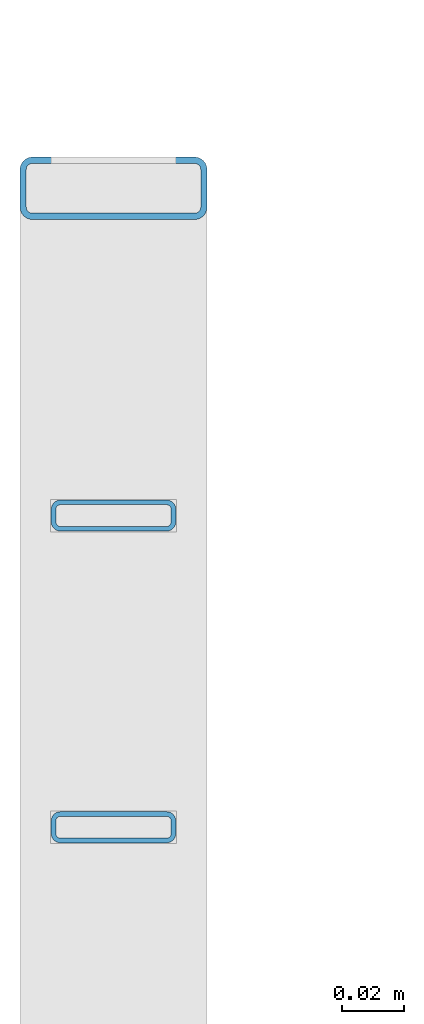
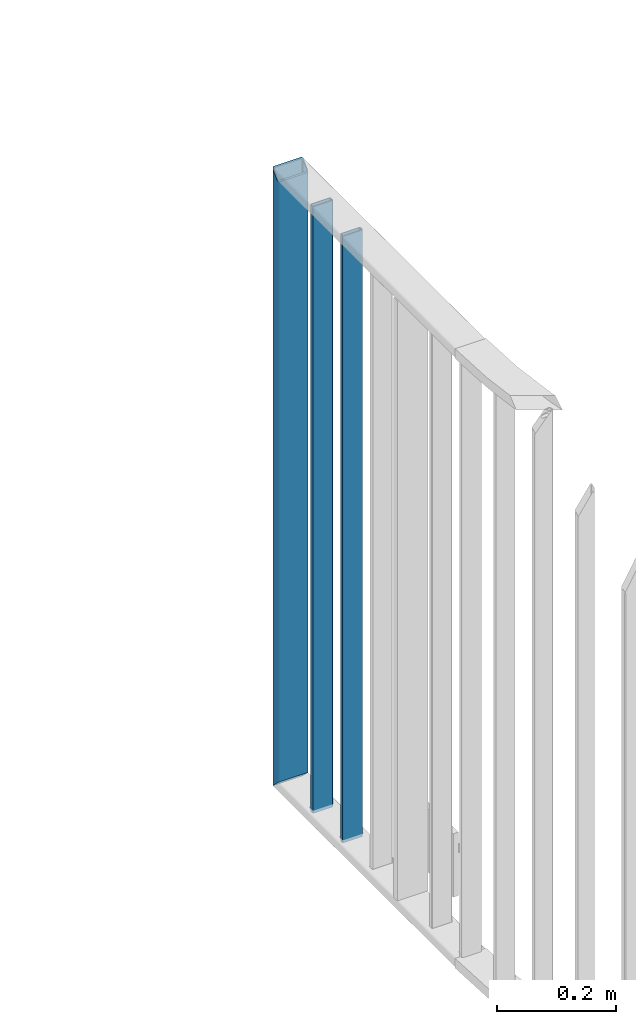
# One storey, part 5 of 156: 3 beams, 1 element without a shape of its own.
"""IFC2X3 building model written with IfcOpenShell, lengths in millimetres."""

from ifc_helpers import new_model, si_unit, frame, origin_with_axes, origin_2d_with_axis, place, context, subcontext, project, spatial, hollow_rectangle, extrude, clip, halfspace, material, type_object, element, aggregate, save


model = new_model("IFC2X3")

# Units and contexts
model_context = context("Model", 3, precision=1e-05, world=origin_with_axes())
body_context = subcontext(model_context, "Body", "Model", "MODEL_VIEW")
ifc_project = project(units=[si_unit("LENGTHUNIT", "METRE", prefix="MILLI"), si_unit("AREAUNIT", "SQUARE_METRE"), si_unit("VOLUMEUNIT", "CUBIC_METRE"), si_unit("MASSUNIT", "GRAM", prefix="KILO"), si_unit("TIMEUNIT", "SECOND"), si_unit("PLANEANGLEUNIT", "RADIAN"), si_unit("SOLIDANGLEUNIT", "STERADIAN"), si_unit("THERMODYNAMICTEMPERATUREUNIT", "DEGREE_CELSIUS"), si_unit("LUMINOUSINTENSITYUNIT", "LUMEN")], contexts=[model_context])

# Site, building, storey
site_placement = place(None, origin_with_axes())
site = spatial("IfcSite", under=ifc_project, at=site_placement, CompositionType="ELEMENT")
building_placement = place(site_placement, origin_with_axes())
building = spatial("IfcBuilding", under=site, at=building_placement, Name="Undefined", CompositionType="ELEMENT")
storey_placement = place(building_placement, origin_with_axes())
storey = spatial("IfcBuildingStorey", under=building, at=storey_placement, Name="Undefined", CompositionType="ELEMENT", Elevation=0.0)

# Assembly, beams
assembly_placement = place(storey_placement, origin_with_axes())
assembly = element("IfcElementAssembly", 1, at=assembly_placement, inside=storey, AssemblyPlace="NOTDEFINED", PredefinedType="RIGID_FRAME")
ifc_material = material(Name="STEEL/S235JR")
beam_type_1 = type_object("IfcBeamType", Name="K60/20/2", PredefinedType="NOTDEFINED")
beam_1_placement = place(assembly_placement, frame((8217.00163269043, 12744.9989152158, 4000.0), z_axis=(1.0, 0.0, 0.0), x_axis=(0.0, 0.0, -1.0)))
beam_1 = element("IfcBeam", 2, at=beam_1_placement, type_object=beam_type_1, material=ifc_material, ObjectType="K60/20/2", context=body_context, shape_type="Clipping", body=[
    clip(clip(extrude(hollow_rectangle(XDim=20.0, YDim=60.0, WallThickness=2.0, InnerFilletRadius=2.0, OuterFilletRadius=4.0, at=origin_2d_with_axis()), frame((1280.2, 0.0, 0.0), z_axis=(-1.0, 0.0, 0.0), x_axis=(0.0, -1.0, 0.0)), (0.0, 0.0, 1.0), 1290.4), halfspace(frame((1250.0, -10.0, -0.002166748046875), z_axis=(-0.707106781186548, 0.707106781186548, 0.0), x_axis=(0.0, 0.0, -1.0)), True)), halfspace(frame((0.0, 10.0000000000146, 0.0), z_axis=(-0.707106781186548, -0.707106781186548, 0.0), x_axis=(0.0, 0.0, 1.0)), False)),
])
beam_type_2 = type_object("IfcBeamType", Name="K40/10/1.5", PredefinedType="NOTDEFINED")
beam_2_placement = place(assembly_placement, frame((8216.99947364132, 12539.9989152168, 3980.00000000003), z_axis=(1.0, 0.0, 0.0), x_axis=(0.0, 0.0, -1.0)))
beam_2 = element("IfcBeam", 3, at=beam_2_placement, type_object=beam_type_2, material=ifc_material, ObjectType="K40/10/1.5", context=body_context, shape_type="Clipping", body=[
    clip(clip(extrude(hollow_rectangle(XDim=10.0, YDim=40.0, WallThickness=1.5, InnerFilletRadius=1.5, OuterFilletRadius=3.0, at=origin_2d_with_axis()), frame((1237.00000000003, 0.0, 0.0), z_axis=(-1.0, 0.0, 0.0), x_axis=(0.0, -1.0, 0.0)), (0.0, 0.0, 1.0), 1244.0), halfspace(frame((1237.00000000003, -56.3749450640607, -3.21677039569113), z_axis=(1.0, 0.0, 0.0), x_axis=(0.0, -0.0578016017852366, -0.998328089773628)), False)), halfspace(frame((-6.99999999997408, 56.3749450528248, -3.21677038838243), z_axis=(-1.0, 0.0, 0.0), x_axis=(0.0, 0.0578016019523036, -0.998328089763955)), False)),
])
beam_3_placement = place(assembly_placement, frame((8216.99947364132, 12639.9989152168, 3980.00000000003), z_axis=(1.0, 0.0, 0.0), x_axis=(0.0, 0.0, -1.0)))
beam_3 = element("IfcBeam", 4, at=beam_3_placement, type_object=beam_type_2, material=ifc_material, ObjectType="K40/10/1.5", context=body_context, shape_type="Clipping", body=[
    clip(clip(extrude(hollow_rectangle(XDim=10.0, YDim=40.0, WallThickness=1.5, InnerFilletRadius=1.5, OuterFilletRadius=3.0, at=origin_2d_with_axis()), frame((1237.00000000003, 0.0, 0.0), z_axis=(-1.0, 0.0, 0.0), x_axis=(0.0, -1.0, 0.0)), (0.0, 0.0, 1.0), 1244.0), halfspace(frame((1237.00000000003, -56.3749450640607, -3.21677039569113), z_axis=(1.0, 0.0, 0.0), x_axis=(0.0, -0.0578016017852366, -0.998328089773628)), False)), halfspace(frame((-6.99999999997408, 56.3749450528248, -3.21677038838243), z_axis=(-1.0, 0.0, 0.0), x_axis=(0.0, 0.0578016019523036, -0.998328089763955)), False)),
])
aggregate(assembly, [beam_2, beam_1, beam_3])

save(model, "model.ifc")
